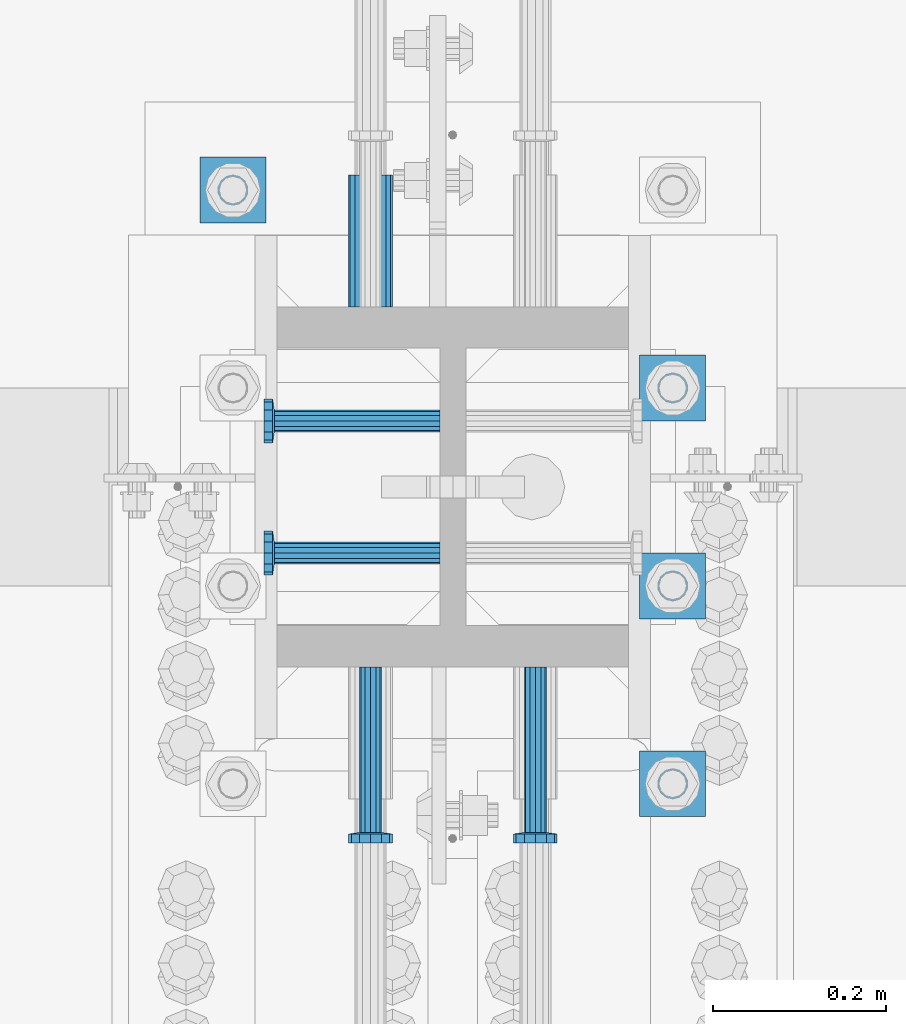
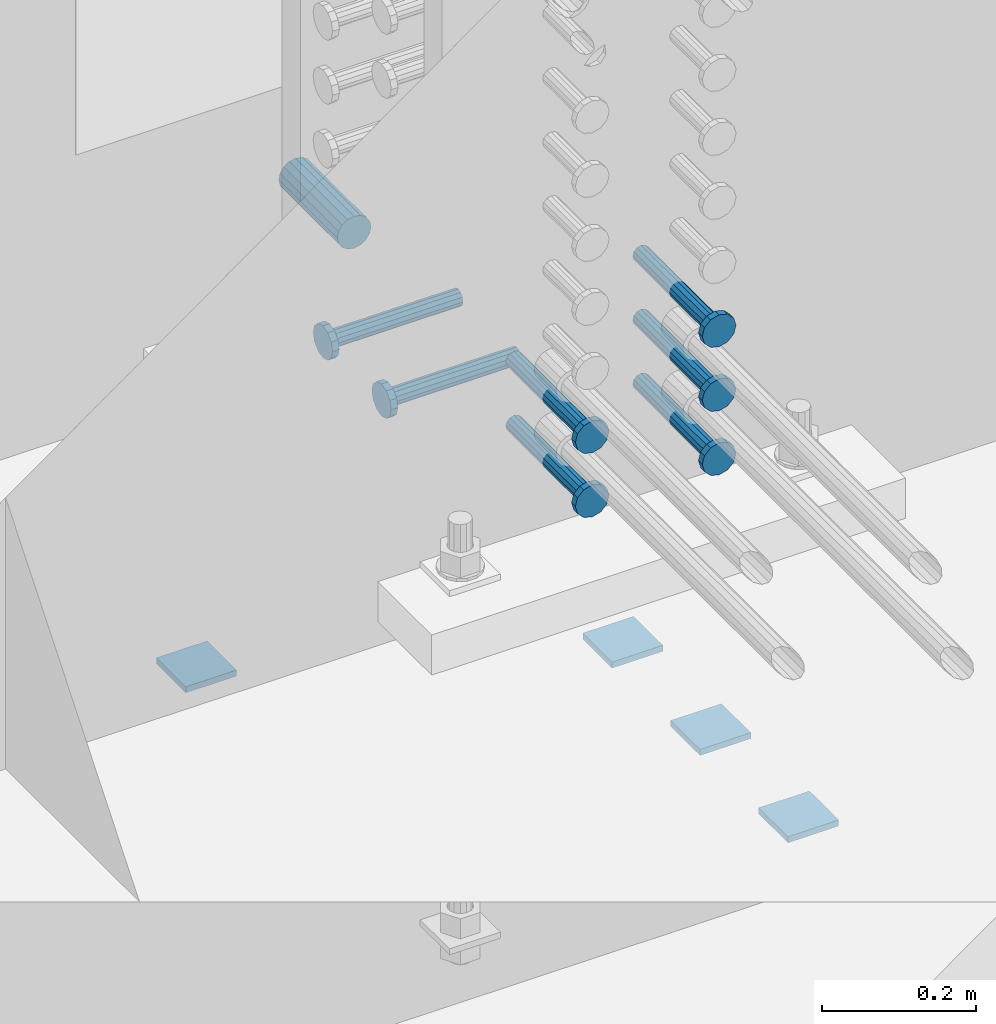
# One storey, part 1320 of 1763: 12 beams, 2 elements without a shape of their own.
"""IFC2X3 building model written with IfcOpenShell, lengths in millimetres."""

import ifcopenshell
import ifcopenshell.guid

model = None  # the IFC model being written
_history = None  # IfcOwnerHistory: only IFC2X3 demands one
_inside = {}  # id of a spatial element -> (the spatial element, [elements in it])
_under = {}  # id of a project, library or spatial element -> (it, [spatial elements below it])
_declared = {}  # id of a project -> (the project, [libraries it declares])
_typed = {}  # id of a type object -> (the type object, [elements of that type])
_made_of = {}  # id of a material, layer set ... -> (it, [elements and type objects made of it])


def new_model(schema):
    """Start an empty IFC model of exactly this schema.

    Asked for "IFC4X3", IfcOpenShell would pick the latest addendum, in which some entities
    have other attributes; the version numbers below select the first issue.
    IFC2X3 requires an IfcOwnerHistory on every rooted entity: one is made here for all.
    """
    global model, _history
    if schema == "IFC4X3":
        model = ifcopenshell.file(schema_version=(4, 3, 0, 0))
    else:
        model = ifcopenshell.file(schema=schema)
    _inside.clear()
    _under.clear()
    _declared.clear()
    _typed.clear()
    _made_of.clear()
    _history = None
    if model.schema == "IFC2X3":
        org = make("IfcOrganization", Name="unknown")
        user = make(
            "IfcPersonAndOrganization",
            ThePerson=make("IfcPerson", FamilyName="unknown"),
            TheOrganization=org,
        )
        app = make(
            "IfcApplication",
            ApplicationDeveloper=org,
            Version="unknown",
            ApplicationFullName="unknown",
            ApplicationIdentifier="unknown",
        )
        _history = make(
            "IfcOwnerHistory",
            OwningUser=user,
            OwningApplication=app,
            ChangeAction="ADDED",
            CreationDate=0,
        )
    return model


def make(cls, **values):
    """One entity of the class cls with the attributes given. An attribute that is None is left unset."""
    return model.create_entity(
        cls, **{name: value for name, value in values.items() if value is not None}
    )


def rooted(cls, **values):
    """An entity with a GlobalId (a new one), such as an element, a storey or a relation."""
    return make(cls, GlobalId=ifcopenshell.guid.new(), OwnerHistory=_history, **values)


def si_unit(unit_type, name, prefix=None):
    """IfcSIUnit, for example si_unit("LENGTHUNIT", "METRE", prefix="MILLI")."""
    return make("IfcSIUnit", UnitType=unit_type, Prefix=prefix, Name=name)


def assignment(units):
    """IfcUnitAssignment: the units of a project."""
    return None if units is None else make("IfcUnitAssignment", Units=units)


def point(xyz):
    """IfcCartesianPoint."""
    return None if xyz is None else make("IfcCartesianPoint", Coordinates=xyz)


def direction(xyz):
    """IfcDirection."""
    return None if xyz is None else make("IfcDirection", DirectionRatios=xyz)


def frame(location, z_axis=None, x_axis=None):
    """IfcAxis2Placement3D, a coordinate frame: its origin and axes. An axis left out is left unset."""
    return make(
        "IfcAxis2Placement3D",
        Location=point(location),
        Axis=direction(z_axis),
        RefDirection=direction(x_axis),
    )


def origin_with_axes():
    """The frame at (0, 0, 0) with the z axis (0, 0, 1) and the x axis (1, 0, 0) written out."""
    return frame((0.0, 0.0, 0.0), z_axis=(0.0, 0.0, 1.0), x_axis=(1.0, 0.0, 0.0))


def place(relative_to, where):
    """IfcLocalPlacement: puts the frame where relative to a parent placement (None: the world)."""
    return make(
        "IfcLocalPlacement", PlacementRelTo=relative_to, RelativePlacement=where
    )


def context(
    kind, dimensions, precision=None, world=None, true_north=None, identifier=None
):
    """IfcGeometricRepresentationContext, for example the 3D "Model" context."""
    return make(
        "IfcGeometricRepresentationContext",
        ContextIdentifier=identifier,
        ContextType=kind,
        CoordinateSpaceDimension=dimensions,
        Precision=precision,
        WorldCoordinateSystem=world,
        TrueNorth=true_north,
    )


def subcontext(parent, identifier, kind, view, scale=None):
    """IfcGeometricRepresentationSubContext, for example "Body" below "Model"."""
    return make(
        "IfcGeometricRepresentationSubContext",
        ContextIdentifier=identifier,
        ContextType=kind,
        ParentContext=parent,
        TargetScale=scale,
        TargetView=view,
    )


def project(units=None, contexts=None):
    """IfcProject with its units and contexts."""
    return rooted(
        "IfcProject",
        Name="project",
        RepresentationContexts=contexts,
        UnitsInContext=assignment(units),
    )


def spatial(cls, under=None, at=None, **own):
    """A site, building, storey or space (cls), placed at a placement, below another one or the project."""
    s = rooted(cls, ObjectPlacement=at, **own)
    if under is not None:
        _under.setdefault(under.id(), (under, []))[1].append(s)
    return s


def faces_of(points, faces, orient=None, outer=None):
    """IfcFace entities. A face is a list of loops; a loop is a list of indices into points, from 0.

    orient and outer hold one flag for each loop. By default every Orientation is true, the
    first loop of a face is its IfcFaceOuterBound and the others are IfcFaceBound.
    """
    made = []
    for i, loops in enumerate(faces):
        bounds = []
        for j, loop in enumerate(loops):
            is_outer = j == 0 if outer is None else outer[i][j]
            bounds.append(
                make(
                    "IfcFaceOuterBound" if is_outer else "IfcFaceBound",
                    Bound=make("IfcPolyLoop", Polygon=[points[k] for k in loop]),
                    Orientation=True if orient is None else orient[i][j],
                )
            )
        made.append(make("IfcFace", Bounds=bounds))
    return made


def faceted_brep(points, faces, orient=None, outer=None, voids=None):
    """IfcFacetedBrep: a solid bounded by flat faces; with voids (closed shells), ...WithVoids."""
    shared = [point(p) for p in points]
    hull = make("IfcClosedShell", CfsFaces=faces_of(shared, faces, orient, outer))
    if voids is None:
        return make("IfcFacetedBrep", Outer=hull)
    return make(
        "IfcFacetedBrepWithVoids",
        Outer=hull,
        Voids=[
            make(cls, CfsFaces=faces_of(shared, fs, o, b)) for cls, fs, o, b in voids
        ],
    )


def shape(context_of_items, identifier, shape_type, items):
    """IfcShapeRepresentation: the items that make up one representation, for example the "Body"."""
    return make(
        "IfcShapeRepresentation",
        ContextOfItems=context_of_items,
        RepresentationIdentifier=identifier,
        RepresentationType=shape_type,
        Items=items,
    )


def material(Name=None, Category=None):
    """IfcMaterial."""
    return make("IfcMaterial", Name=Name, Category=Category)


def made_of(thing, what):
    """Note that an element or type object is made of a material, layer set ...; save() writes the relation."""
    if what is not None:
        _made_of.setdefault(what.id(), (what, []))[1].append(thing)
    return thing


def type_object(cls, material=None, **own):
    """A type object (cls), such as IfcWallType, which elements share."""
    return made_of(rooted(cls, **own), material)


def element(
    cls,
    number,
    at=None,
    inside=None,
    cuts=None,
    type_object=None,
    material=None,
    context=None,
    identifier="Body",
    shape_type=None,
    held_by="IfcProductDefinitionShape",
    body=None,
    shapes=None,
    **own,
):
    """One element of the class cls, such as IfcWall. Its Tag is "e" and its number.

    at: its placement. inside: the storey or other place that contains it. cuts: it is an
    opening in that element (IfcRelVoidsElement). A single representation is given by context,
    identifier, shape_type and body (its items); several are given by shapes. held_by: the class
    of the entity that holds the representations. save() writes the other relations.
    """
    e = rooted(cls, Tag="e%d" % number, ObjectPlacement=at, **own)
    if body is not None:
        shapes = [shape(context, identifier, shape_type, body)]
    if shapes is not None:
        e.Representation = make(held_by, Representations=shapes)
    if inside is not None:
        _inside.setdefault(inside.id(), (inside, []))[1].append(e)
    if cuts is not None:
        rooted(
            "IfcRelVoidsElement", RelatingBuildingElement=cuts, RelatedOpeningElement=e
        )
    if type_object is not None:
        _typed.setdefault(type_object.id(), (type_object, []))[1].append(e)
    return made_of(e, material)


def aggregate(whole, parts):
    """IfcRelAggregates: a whole, such as a stair, and the parts it consists of."""
    return rooted("IfcRelAggregates", RelatingObject=whole, RelatedObjects=parts)


def save(model, path):
    """Write the relations noted so far, then the file.

    IfcRelAggregates (storeys below a building ...), IfcRelContainedInSpatialStructure (elements
    in a storey), IfcRelDefinesByType, IfcRelAssociatesMaterial and IfcRelDeclares: one each for
    every whole, place, type object, material and project.
    """
    for whole, parts in _under.values():
        aggregate(whole, parts)
    for where, things in _inside.values():
        rooted(
            "IfcRelContainedInSpatialStructure",
            RelatedElements=things,
            RelatingStructure=where,
        )
    for kind, things in _typed.values():
        rooted("IfcRelDefinesByType", RelatedObjects=things, RelatingType=kind)
    for what, things in _made_of.values():
        rooted("IfcRelAssociatesMaterial", RelatedObjects=things, RelatingMaterial=what)
    for by, libraries in _declared.values():
        rooted("IfcRelDeclares", RelatingContext=by, RelatedDefinitions=libraries)
    model.write(path)


model = new_model("IFC2X3")

# Units and contexts
model_context = context("Model", 3, precision=1e-05, world=origin_with_axes())
body_context = subcontext(model_context, "Body", "Model", "MODEL_VIEW")
ifc_project = project(units=[si_unit("LENGTHUNIT", "METRE", prefix="MILLI"), si_unit("AREAUNIT", "SQUARE_METRE"), si_unit("VOLUMEUNIT", "CUBIC_METRE"), si_unit("MASSUNIT", "GRAM", prefix="KILO"), si_unit("TIMEUNIT", "SECOND"), si_unit("PLANEANGLEUNIT", "RADIAN"), si_unit("SOLIDANGLEUNIT", "STERADIAN"), si_unit("THERMODYNAMICTEMPERATUREUNIT", "DEGREE_CELSIUS"), si_unit("LUMINOUSINTENSITYUNIT", "LUMEN")], contexts=[model_context])

# Site, building, storey
site_placement = place(None, origin_with_axes())
site = spatial("IfcSite", under=ifc_project, at=site_placement, CompositionType="ELEMENT")
building_placement = place(site_placement, origin_with_axes())
building = spatial("IfcBuilding", under=site, at=building_placement, Name="Undefined", CompositionType="ELEMENT")
storey_placement = place(building_placement, origin_with_axes())
storey = spatial("IfcBuildingStorey", under=building, at=storey_placement, Name="Undefined", CompositionType="ELEMENT", Elevation=0.0)

# Assembly, beams
assembly_1_placement = place(storey_placement, origin_with_axes())
assembly_1 = element("IfcElementAssembly", 1, at=assembly_1_placement, inside=storey, Name="TEMPLATE", AssemblyPlace="NOTDEFINED", PredefinedType="RIGID_FRAME")
ifc_material_1 = material(Name="STEEL/A36")
beam_type_1 = type_object("IfcBeamType", PredefinedType="NOTDEFINED")
beam_1_placement = place(assembly_1_placement, frame((-23773.8372736984, 13309.5999999999, 3348.0375), z_axis=(1.0, 0.0, 0.0), x_axis=(0.0, 1.0, 0.0)))
beam_1 = element("IfcBeam", 2, at=beam_1_placement, type_object=beam_type_1, material=ifc_material_1, Name="WASHER PLATE", context=body_context, shape_type="Brep", body=[
    faceted_brep([(0.0, 4.76249999999709, -38.1000000000004), (0.0, 4.76249999999709, 38.1000000000004), (76.2000000000007, 4.76249999999982, 38.0999999999985), (76.2000000000007, 4.76249999999982, -38.0999999999985), (0.0, -4.76249999999709, 38.1000000000004), (76.2000000000007, -4.76249999999982, 38.0999999999985), (0.0, -4.76249999999709, -38.1000000000004), (76.2000000000007, -4.76249999999982, -38.0999999999985)], [[[0, 1, 2, 3]], [[1, 4, 5, 2]], [[4, 6, 7, 5]], [[6, 0, 3, 7]], [[5, 7, 3, 2]], [[6, 4, 1, 0]]]),
])
beam_2_placement = place(assembly_1_placement, frame((-23773.8372736984, 13538.1999999999, 3348.0375), z_axis=(1.0, 0.0, 0.0), x_axis=(0.0, 1.0, 0.0)))
beam_2 = element("IfcBeam", 3, at=beam_2_placement, type_object=beam_type_1, material=ifc_material_1, Name="WASHER PLATE", context=body_context, shape_type="Brep", body=[
    faceted_brep([(0.0, 4.76249999999709, -38.1000000000004), (0.0, 4.76249999999709, 38.1000000000004), (76.2000000000007, 4.76249999999982, 38.0999999999985), (76.2000000000007, 4.76249999999982, -38.0999999999985), (0.0, -4.76249999999709, 38.1000000000004), (76.2000000000007, -4.76249999999982, 38.0999999999985), (0.0, -4.76249999999709, -38.1000000000004), (76.2000000000007, -4.76249999999982, -38.0999999999985)], [[[0, 1, 2, 3]], [[1, 4, 5, 2]], [[4, 6, 7, 5]], [[6, 0, 3, 7]], [[5, 7, 3, 2]], [[6, 4, 1, 0]]]),
])
beam_3_placement = place(assembly_1_placement, frame((-23773.8372736984, 13766.7999999999, 3348.0375), z_axis=(1.0, 0.0, 0.0), x_axis=(0.0, 1.0, 0.0)))
beam_3 = element("IfcBeam", 4, at=beam_3_placement, type_object=beam_type_1, material=ifc_material_1, Name="WASHER PLATE", context=body_context, shape_type="Brep", body=[
    faceted_brep([(0.0, 4.76249999999709, -38.1000000000004), (0.0, 4.76249999999709, 38.1000000000004), (76.2000000000007, 4.76249999999982, 38.0999999999985), (76.2000000000007, 4.76249999999982, -38.0999999999985), (0.0, -4.76249999999709, 38.1000000000004), (76.2000000000007, -4.76249999999982, 38.0999999999985), (0.0, -4.76249999999709, -38.1000000000004), (76.2000000000007, -4.76249999999982, -38.0999999999985)], [[[0, 1, 2, 3]], [[1, 4, 5, 2]], [[4, 6, 7, 5]], [[6, 0, 3, 7]], [[5, 7, 3, 2]], [[6, 4, 1, 0]]]),
])
beam_4_placement = place(assembly_1_placement, frame((-24281.8372736984, 13995.3999999999, 3348.0375), z_axis=(1.0, 0.0, 0.0), x_axis=(0.0, 1.0, 0.0)))
beam_4 = element("IfcBeam", 5, at=beam_4_placement, type_object=beam_type_1, material=ifc_material_1, Name="WASHER PLATE", context=body_context, shape_type="Brep", body=[
    faceted_brep([(0.0, 4.76249999999709, -38.1000000000004), (0.0, 4.76249999999709, 38.1000000000004), (76.2000000000007, 4.76249999999982, 38.0999999999985), (76.2000000000007, 4.76249999999982, -38.0999999999985), (0.0, -4.76249999999709, 38.1000000000004), (76.2000000000007, -4.76249999999982, 38.0999999999985), (0.0, -4.76249999999709, -38.1000000000004), (76.2000000000007, -4.76249999999982, -38.0999999999985)], [[[0, 1, 2, 3]], [[1, 4, 5, 2]], [[4, 6, 7, 5]], [[6, 0, 3, 7]], [[5, 7, 3, 2]], [[6, 4, 1, 0]]]),
])
aggregate(assembly_1, [beam_1, beam_2, beam_3, beam_4])

assembly_2_placement = place(storey_placement, origin_with_axes())
assembly_2 = element("IfcElementAssembly", 6, at=assembly_2_placement, inside=storey, Name="COLUMN", AssemblyPlace="NOTDEFINED", PredefinedType="RIGID_FRAME")
ifc_material_2 = material(Name="STEEL/A706-GR.80")
beam_type_2 = type_object("IfcBeamType", PredefinedType="NOTDEFINED")
beam_5_placement = place(assembly_2_placement, frame((-24123.0872736984, 13898.5623171099, 4064.0), z_axis=(0.0, 0.0, 1.0), x_axis=(0.0, 1.0, 0.0)))
beam_5 = element("IfcBeam", 7, at=beam_5_placement, type_object=beam_type_2, material=ifc_material_2, Name="HALF COUPLER F", context=body_context, shape_type="Brep", body=[
    faceted_brep([(32.7659999999996, -8.95349999999962, -15.507916905568), (32.7659999999996, 0.0, -17.9070000000002), (32.7659999999996, 8.95349999999962, -15.507916905568), (32.7659999999996, 15.507916905568, -8.95350000000008), (32.7659999999996, 17.9069999999992, 0.0), (32.7659999999996, 15.507916905568, 8.95350000000008), (32.7659999999996, 8.95349999999962, 15.507916905568), (32.7659999999996, 0.0, 17.9070000000002), (32.7659999999996, -8.95349999999962, 15.507916905568), (32.7659999999996, -15.507916905568, 8.95350000000008), (32.7659999999996, -17.9069999999992, 0.0), (32.7659999999996, -15.507916905568, -8.95350000000008), (152.400103102711, -15.507916905568, 8.95350000000008), (152.400103102711, -8.95349999999962, 15.507916905568), (152.400103102711, -17.9069999999992, 0.0), (152.400103102711, -15.507916905568, -8.95350000000008), (152.400103102711, -8.95349999999962, -15.507916905568), (152.400103102711, 0.0, -17.9070000000002), (152.400103102711, 8.95349999999962, -15.507916905568), (152.400103102711, 15.507916905568, -8.95350000000008), (152.400103102711, 17.9069999999992, 0.0), (152.400103102711, 15.507916905568, 8.95350000000008), (152.400103102711, 8.95349999999962, 15.507916905568), (152.400103102711, 0.0, 17.9070000000002), (0.0, -23.466540125788, 9.72015918207308), (0.0, -17.9605122421381, 17.9605122421385), (0.0, -9.72015918207398, 23.4665401257867), (0.0, 0.0, 25.4000000000001), (0.0, 9.72015918207398, 23.4665401257867), (0.0, 17.9605122421381, 17.9605122421385), (0.0, 23.466540125788, 9.72015918207308), (0.0, 25.4000000000015, 0.0), (0.0, 23.466540125788, -9.72015918207308), (0.0, 17.9605122421381, -17.9605122421385), (0.0, 9.72015918207398, -23.4665401257867), (0.0, 0.0, -25.4000000000001), (0.0, -9.72015918207398, -23.4665401257867), (0.0, -17.9605122421381, -17.9605122421385), (0.0, -23.466540125788, -9.72015918207308), (0.0, -25.4000000000015, 0.0), (152.400103102711, -25.4000000000015, 0.0), (152.400103102711, -23.466540125788, 9.72015918207308), (152.400103102711, -17.9605122421381, 17.9605122421385), (152.400103102711, -9.72015918207398, 23.4665401257867), (152.400103102711, 0.0, 25.4000000000001), (152.400103102711, 9.72015918207398, 23.4665401257867), (152.400103102711, 17.9605122421381, 17.9605122421385), (152.400103102711, 23.466540125788, 9.72015918207308), (152.400103102711, 25.4000000000015, 0.0), (152.400103102711, 23.466540125788, -9.72015918207308), (152.400103102711, 17.9605122421381, -17.9605122421385), (152.400103102711, 9.72015918207398, -23.4665401257867), (152.400103102711, 0.0, -25.4000000000001), (152.400103102711, -9.72015918207398, -23.4665401257867), (152.400103102711, -17.9605122421381, -17.9605122421385), (152.400103102711, -23.466540125788, -9.72015918207308)], [[[0, 1, 2, 3, 4, 5, 6, 7, 8, 9, 10, 11]], [[12, 9, 8, 13]], [[14, 10, 9, 12]], [[15, 11, 10, 14]], [[16, 0, 11, 15]], [[17, 1, 0, 16]], [[18, 2, 1, 17]], [[19, 3, 2, 18]], [[20, 4, 3, 19]], [[21, 5, 4, 20]], [[22, 6, 5, 21]], [[23, 7, 6, 22]], [[13, 8, 7, 23]], [[24, 25, 26, 27, 28, 29, 30, 31, 32, 33, 34, 35, 36, 37, 38, 39]], [[24, 39, 40, 41]], [[25, 24, 41, 42]], [[26, 25, 42, 43]], [[27, 26, 43, 44]], [[28, 27, 44, 45]], [[29, 28, 45, 46]], [[30, 29, 46, 47]], [[31, 30, 47, 48]], [[32, 31, 48, 49]], [[33, 32, 49, 50]], [[34, 33, 50, 51]], [[35, 34, 51, 52]], [[36, 35, 52, 53]], [[37, 36, 53, 54]], [[38, 37, 54, 55]], [[39, 38, 55, 40]], [[54, 53, 52, 51, 50, 49, 48, 47, 46, 45, 44, 43, 42, 41, 40, 55], [21, 20, 19, 18, 17, 16, 15, 14, 12, 13, 23, 22]]]),
])
ifc_material_3 = material(Name="STEEL/A108")
beam_type_3 = type_object("IfcBeamType", PredefinedType="NOTDEFINED")
beam_6_placement = place(assembly_2_placement, frame((-23932.5872736984, 13482.6374312644, 4216.40000000002), z_axis=(1.0, 0.0, 0.0), x_axis=(0.0, -1.0, 0.0)))
beam_6 = element("IfcBeam", 8, at=beam_6_placement, type_object=beam_type_3, material=ifc_material_3, Name="HEADED STUD ANCHOR", context=body_context, shape_type="Brep", body=[
    faceted_brep([(0.0, -12.6999999999971, -1.81898940354586e-12), (3.63797880709171e-12, -11.0, -6.34999990463257), (191.00799999576, -11.0, -6.34999990454889), (191.007999995752, -12.6999998092651, 8.36735125631094e-11), (7.27595761418343e-12, -6.34999990463257, -11.0), (191.00799999576, -6.34999990463257, -10.9999999999163), (3.63797880709171e-12, 0.0, -12.6999998092651), (191.00799999576, 0.0, -12.6999998091815), (7.27595761418343e-12, 6.34999990463257, -11.0), (191.00799999576, 6.34999990463257, -10.9999999999163), (3.63797880709171e-12, 11.0, -6.34999990463257), (191.00799999576, 11.0, -6.34999990454889), (0.0, 12.6999999999971, -1.81898940354586e-12), (191.007999995752, 12.6999998092651, 8.36735125631094e-11), (0.0, 11.0, 6.34999990463257), (191.007999995752, 11.0, 6.34999990471624), (-3.63797880709171e-12, 6.34999990463257, 11.0), (191.007999995749, 6.34999990463257, 11.0000000000837), (-3.63797880709171e-12, 0.0, 12.6999998092651), (191.007999995749, 0.0, 12.6999998093488), (-3.63797880709171e-12, -6.34999990463257, 11.0), (191.007999995749, -6.34999990463257, 11.0000000000837), (0.0, -11.0, 6.34999990463257), (191.007999995752, -11.0, 6.34999990471624), (193.039999995715, -22.0, -12.6999998091796), (193.039999995708, -25.3999996185303, 8.54925019666553e-11), (193.039999995719, -12.6999998092651, -21.9999999999145), (193.039999995719, 0.0, -25.3999996184448), (193.039999995719, 12.6999998092651, -21.9999999999145), (193.039999995715, 22.0, -12.6999998091796), (193.039999995708, 25.3999996185303, 8.54925019666553e-11), (193.039999995704, 22.0, 12.6999998093506), (193.039999995701, 12.6999998092651, 22.0000000000855), (193.039999995697, 0.0, 25.3999996186158), (193.039999995701, -12.6999998092651, 22.0000000000855), (193.039999995704, -22.0, 12.6999998093506), (203.199999995486, -22.0, -12.6999998091742), (203.199999995482, -25.3999996185303, 9.09494701772928e-11), (203.199999995493, -12.6999998092651, -21.9999999999091), (203.199999995493, 0.0, -25.3999996184393), (203.199999995493, 12.6999998092651, -21.9999999999091), (203.199999995486, 22.0, -12.6999998091742), (203.199999995482, 25.3999996185303, 9.09494701772928e-11), (203.199999995479, 22.0, 12.6999998093561), (203.199999995475, 12.6999998092651, 22.0000000000909), (203.199999995471, 0.0, 25.3999996186212), (203.199999995475, -12.6999998092651, 22.0000000000909), (203.199999995479, -22.0, 12.6999998093561)], [[[0, 1, 2, 3]], [[1, 4, 5, 2]], [[4, 6, 7, 5]], [[6, 8, 9, 7]], [[8, 10, 11, 9]], [[10, 12, 13, 11]], [[12, 14, 15, 13]], [[14, 16, 17, 15]], [[16, 18, 19, 17]], [[18, 20, 21, 19]], [[20, 22, 23, 21]], [[22, 0, 3, 23]], [[22, 20, 18, 16, 14, 12, 10, 8, 6, 4, 1, 0]], [[3, 2, 24, 25]], [[2, 5, 26, 24]], [[5, 7, 27, 26]], [[7, 9, 28, 27]], [[9, 11, 29, 28]], [[11, 13, 30, 29]], [[13, 15, 31, 30]], [[15, 17, 32, 31]], [[17, 19, 33, 32]], [[19, 21, 34, 33]], [[21, 23, 35, 34]], [[23, 3, 25, 35]], [[25, 24, 36, 37]], [[24, 26, 38, 36]], [[26, 27, 39, 38]], [[27, 28, 40, 39]], [[28, 29, 41, 40]], [[29, 30, 42, 41]], [[30, 31, 43, 42]], [[31, 32, 44, 43]], [[32, 33, 45, 44]], [[33, 34, 46, 45]], [[34, 35, 47, 46]], [[35, 25, 37, 47]], [[38, 39, 40, 41, 42, 43, 44, 45, 46, 47, 37, 36]]]),
])
beam_7_placement = place(assembly_2_placement, frame((-24123.0872736978, 13482.6374999249, 4114.80000000002), z_axis=(1.0, 0.0, 0.0), x_axis=(0.0, -1.0, 0.0)))
beam_7 = element("IfcBeam", 9, at=beam_7_placement, type_object=beam_type_3, material=ifc_material_3, Name="HEADED STUD ANCHOR", context=body_context, shape_type="Brep", body=[
    faceted_brep([(0.0, -12.6999999999971, -1.81898940354586e-12), (3.63797880709171e-12, -11.0, -6.34999990463257), (191.00799999576, -11.0, -6.34999990454889), (191.007999995752, -12.6999998092651, 8.36735125631094e-11), (7.27595761418343e-12, -6.34999990463257, -11.0), (191.00799999576, -6.34999990463257, -10.9999999999163), (3.63797880709171e-12, 0.0, -12.6999998092651), (191.00799999576, 0.0, -12.6999998091815), (7.27595761418343e-12, 6.34999990463257, -11.0), (191.00799999576, 6.34999990463257, -10.9999999999163), (3.63797880709171e-12, 11.0, -6.34999990463257), (191.00799999576, 11.0, -6.34999990454889), (0.0, 12.6999999999971, -1.81898940354586e-12), (191.007999995752, 12.6999998092651, 8.36735125631094e-11), (0.0, 11.0, 6.34999990463257), (191.007999995752, 11.0, 6.34999990471624), (-3.63797880709171e-12, 6.34999990463257, 11.0), (191.007999995749, 6.34999990463257, 11.0000000000837), (-3.63797880709171e-12, 0.0, 12.6999998092651), (191.007999995749, 0.0, 12.6999998093488), (-3.63797880709171e-12, -6.34999990463257, 11.0), (191.007999995749, -6.34999990463257, 11.0000000000837), (0.0, -11.0, 6.34999990463257), (191.007999995752, -11.0, 6.34999990471624), (193.039999995715, -22.0, -12.6999998091796), (193.039999995708, -25.3999996185303, 8.54925019666553e-11), (193.039999995719, -12.6999998092651, -21.9999999999145), (193.039999995719, 0.0, -25.3999996184448), (193.039999995719, 12.6999998092651, -21.9999999999145), (193.039999995715, 22.0, -12.6999998091796), (193.039999995708, 25.3999996185303, 8.54925019666553e-11), (193.039999995704, 22.0, 12.6999998093506), (193.039999995701, 12.6999998092651, 22.0000000000855), (193.039999995697, 0.0, 25.3999996186158), (193.039999995701, -12.6999998092651, 22.0000000000855), (193.039999995704, -22.0, 12.6999998093506), (203.199999995486, -22.0, -12.6999998091742), (203.199999995482, -25.3999996185303, 9.09494701772928e-11), (203.199999995493, -12.6999998092651, -21.9999999999091), (203.199999995493, 0.0, -25.3999996184393), (203.199999995493, 12.6999998092651, -21.9999999999091), (203.199999995486, 22.0, -12.6999998091742), (203.199999995482, 25.3999996185303, 9.09494701772928e-11), (203.199999995479, 22.0, 12.6999998093561), (203.199999995475, 12.6999998092651, 22.0000000000909), (203.199999995471, 0.0, 25.3999996186212), (203.199999995475, -12.6999998092651, 22.0000000000909), (203.199999995479, -22.0, 12.6999998093561)], [[[0, 1, 2, 3]], [[1, 4, 5, 2]], [[4, 6, 7, 5]], [[6, 8, 9, 7]], [[8, 10, 11, 9]], [[10, 12, 13, 11]], [[12, 14, 15, 13]], [[14, 16, 17, 15]], [[16, 18, 19, 17]], [[18, 20, 21, 19]], [[20, 22, 23, 21]], [[22, 0, 3, 23]], [[22, 20, 18, 16, 14, 12, 10, 8, 6, 4, 1, 0]], [[3, 2, 24, 25]], [[2, 5, 26, 24]], [[5, 7, 27, 26]], [[7, 9, 28, 27]], [[9, 11, 29, 28]], [[11, 13, 30, 29]], [[13, 15, 31, 30]], [[15, 17, 32, 31]], [[17, 19, 33, 32]], [[19, 21, 34, 33]], [[21, 23, 35, 34]], [[23, 3, 25, 35]], [[25, 24, 36, 37]], [[24, 26, 38, 36]], [[26, 27, 39, 38]], [[27, 28, 40, 39]], [[28, 29, 41, 40]], [[29, 30, 42, 41]], [[30, 31, 43, 42]], [[31, 32, 44, 43]], [[32, 33, 45, 44]], [[33, 34, 46, 45]], [[34, 35, 47, 46]], [[35, 25, 37, 47]], [[38, 39, 40, 41, 42, 43, 44, 45, 46, 47, 37, 36]]]),
])
beam_8_placement = place(assembly_2_placement, frame((-23932.5872736984, 13482.6374312644, 4114.80000000002), z_axis=(1.0, 0.0, 0.0), x_axis=(0.0, -1.0, 0.0)))
beam_8 = element("IfcBeam", 10, at=beam_8_placement, type_object=beam_type_3, material=ifc_material_3, Name="HEADED STUD ANCHOR", context=body_context, shape_type="Brep", body=[
    faceted_brep([(0.0, -12.6999999999971, -1.81898940354586e-12), (3.63797880709171e-12, -11.0, -6.34999990463257), (191.00799999576, -11.0, -6.34999990454889), (191.007999995752, -12.6999998092651, 8.36735125631094e-11), (7.27595761418343e-12, -6.34999990463257, -11.0), (191.00799999576, -6.34999990463257, -10.9999999999163), (3.63797880709171e-12, 0.0, -12.6999998092651), (191.00799999576, 0.0, -12.6999998091815), (7.27595761418343e-12, 6.34999990463257, -11.0), (191.00799999576, 6.34999990463257, -10.9999999999163), (3.63797880709171e-12, 11.0, -6.34999990463257), (191.00799999576, 11.0, -6.34999990454889), (0.0, 12.6999999999971, -1.81898940354586e-12), (191.007999995752, 12.6999998092651, 8.36735125631094e-11), (0.0, 11.0, 6.34999990463257), (191.007999995752, 11.0, 6.34999990471624), (-3.63797880709171e-12, 6.34999990463257, 11.0), (191.007999995749, 6.34999990463257, 11.0000000000837), (-3.63797880709171e-12, 0.0, 12.6999998092651), (191.007999995749, 0.0, 12.6999998093488), (-3.63797880709171e-12, -6.34999990463257, 11.0), (191.007999995749, -6.34999990463257, 11.0000000000837), (0.0, -11.0, 6.34999990463257), (191.007999995752, -11.0, 6.34999990471624), (193.039999995715, -22.0, -12.6999998091796), (193.039999995708, -25.3999996185303, 8.54925019666553e-11), (193.039999995719, -12.6999998092651, -21.9999999999145), (193.039999995719, 0.0, -25.3999996184448), (193.039999995719, 12.6999998092651, -21.9999999999145), (193.039999995715, 22.0, -12.6999998091796), (193.039999995708, 25.3999996185303, 8.54925019666553e-11), (193.039999995704, 22.0, 12.6999998093506), (193.039999995701, 12.6999998092651, 22.0000000000855), (193.039999995697, 0.0, 25.3999996186158), (193.039999995701, -12.6999998092651, 22.0000000000855), (193.039999995704, -22.0, 12.6999998093506), (203.199999995486, -22.0, -12.6999998091742), (203.199999995482, -25.3999996185303, 9.09494701772928e-11), (203.199999995493, -12.6999998092651, -21.9999999999091), (203.199999995493, 0.0, -25.3999996184393), (203.199999995493, 12.6999998092651, -21.9999999999091), (203.199999995486, 22.0, -12.6999998091742), (203.199999995482, 25.3999996185303, 9.09494701772928e-11), (203.199999995479, 22.0, 12.6999998093561), (203.199999995475, 12.6999998092651, 22.0000000000909), (203.199999995471, 0.0, 25.3999996186212), (203.199999995475, -12.6999998092651, 22.0000000000909), (203.199999995479, -22.0, 12.6999998093561)], [[[0, 1, 2, 3]], [[1, 4, 5, 2]], [[4, 6, 7, 5]], [[6, 8, 9, 7]], [[8, 10, 11, 9]], [[10, 12, 13, 11]], [[12, 14, 15, 13]], [[14, 16, 17, 15]], [[16, 18, 19, 17]], [[18, 20, 21, 19]], [[20, 22, 23, 21]], [[22, 0, 3, 23]], [[22, 20, 18, 16, 14, 12, 10, 8, 6, 4, 1, 0]], [[3, 2, 24, 25]], [[2, 5, 26, 24]], [[5, 7, 27, 26]], [[7, 9, 28, 27]], [[9, 11, 29, 28]], [[11, 13, 30, 29]], [[13, 15, 31, 30]], [[15, 17, 32, 31]], [[17, 19, 33, 32]], [[19, 21, 34, 33]], [[21, 23, 35, 34]], [[23, 3, 25, 35]], [[25, 24, 36, 37]], [[24, 26, 38, 36]], [[26, 27, 39, 38]], [[27, 28, 40, 39]], [[28, 29, 41, 40]], [[29, 30, 42, 41]], [[30, 31, 43, 42]], [[31, 32, 44, 43]], [[32, 33, 45, 44]], [[33, 34, 46, 45]], [[34, 35, 47, 46]], [[35, 25, 37, 47]], [[38, 39, 40, 41, 42, 43, 44, 45, 46, 47, 37, 36]]]),
])
beam_9_placement = place(assembly_2_placement, frame((-24042.9185299162, 13766.799999658, 4013.2), z_axis=(0.0, -1.0, 0.0), x_axis=(-1.0, 0.0, 0.0)))
beam_9 = element("IfcBeam", 11, at=beam_9_placement, type_object=beam_type_3, material=ifc_material_3, Name="HEADED STUD ANCHOR", context=body_context, shape_type="Brep", body=[
    faceted_brep([(0.0, -12.6999999999971, -1.81898940354586e-12), (3.63797880709171e-12, -11.0, -6.34999990463257), (191.00799999576, -11.0, -6.34999990454889), (191.007999995752, -12.6999998092651, 8.36735125631094e-11), (7.27595761418343e-12, -6.34999990463257, -11.0), (191.00799999576, -6.34999990463257, -10.9999999999163), (3.63797880709171e-12, 0.0, -12.6999998092651), (191.00799999576, 0.0, -12.6999998091815), (7.27595761418343e-12, 6.34999990463257, -11.0), (191.00799999576, 6.34999990463257, -10.9999999999163), (3.63797880709171e-12, 11.0, -6.34999990463257), (191.00799999576, 11.0, -6.34999990454889), (0.0, 12.6999999999971, -1.81898940354586e-12), (191.007999995752, 12.6999998092651, 8.36735125631094e-11), (0.0, 11.0, 6.34999990463257), (191.007999995752, 11.0, 6.34999990471624), (-3.63797880709171e-12, 6.34999990463257, 11.0), (191.007999995749, 6.34999990463257, 11.0000000000837), (-3.63797880709171e-12, 0.0, 12.6999998092651), (191.007999995749, 0.0, 12.6999998093488), (-3.63797880709171e-12, -6.34999990463257, 11.0), (191.007999995749, -6.34999990463257, 11.0000000000837), (0.0, -11.0, 6.34999990463257), (191.007999995752, -11.0, 6.34999990471624), (193.039999995715, -22.0, -12.6999998091796), (193.039999995708, -25.3999996185303, 8.54925019666553e-11), (193.039999995719, -12.6999998092651, -21.9999999999145), (193.039999995719, 0.0, -25.3999996184448), (193.039999995719, 12.6999998092651, -21.9999999999145), (193.039999995715, 22.0, -12.6999998091796), (193.039999995708, 25.3999996185303, 8.54925019666553e-11), (193.039999995704, 22.0, 12.6999998093506), (193.039999995701, 12.6999998092651, 22.0000000000855), (193.039999995697, 0.0, 25.3999996186158), (193.039999995701, -12.6999998092651, 22.0000000000855), (193.039999995704, -22.0, 12.6999998093506), (203.199999995486, -22.0, -12.6999998091742), (203.199999995482, -25.3999996185303, 9.09494701772928e-11), (203.199999995493, -12.6999998092651, -21.9999999999091), (203.199999995493, 0.0, -25.3999996184393), (203.199999995493, 12.6999998092651, -21.9999999999091), (203.199999995486, 22.0, -12.6999998091742), (203.199999995482, 25.3999996185303, 9.09494701772928e-11), (203.199999995479, 22.0, 12.6999998093561), (203.199999995475, 12.6999998092651, 22.0000000000909), (203.199999995471, 0.0, 25.3999996186212), (203.199999995475, -12.6999998092651, 22.0000000000909), (203.199999995479, -22.0, 12.6999998093561)], [[[0, 1, 2, 3]], [[1, 4, 5, 2]], [[4, 6, 7, 5]], [[6, 8, 9, 7]], [[8, 10, 11, 9]], [[10, 12, 13, 11]], [[12, 14, 15, 13]], [[14, 16, 17, 15]], [[16, 18, 19, 17]], [[18, 20, 21, 19]], [[20, 22, 23, 21]], [[22, 0, 3, 23]], [[22, 20, 18, 16, 14, 12, 10, 8, 6, 4, 1, 0]], [[3, 2, 24, 25]], [[2, 5, 26, 24]], [[5, 7, 27, 26]], [[7, 9, 28, 27]], [[9, 11, 29, 28]], [[11, 13, 30, 29]], [[13, 15, 31, 30]], [[15, 17, 32, 31]], [[17, 19, 33, 32]], [[19, 21, 34, 33]], [[21, 23, 35, 34]], [[23, 3, 25, 35]], [[25, 24, 36, 37]], [[24, 26, 38, 36]], [[26, 27, 39, 38]], [[27, 28, 40, 39]], [[28, 29, 41, 40]], [[29, 30, 42, 41]], [[30, 31, 43, 42]], [[31, 32, 44, 43]], [[32, 33, 45, 44]], [[33, 34, 46, 45]], [[34, 35, 47, 46]], [[35, 25, 37, 47]], [[38, 39, 40, 41, 42, 43, 44, 45, 46, 47, 37, 36]]]),
])
beam_10_placement = place(assembly_2_placement, frame((-24042.9185298019, 13614.3999996589, 4013.2), z_axis=(0.0, -1.0, 0.0), x_axis=(-1.0, 0.0, 0.0)))
beam_10 = element("IfcBeam", 12, at=beam_10_placement, type_object=beam_type_3, material=ifc_material_3, Name="HEADED STUD ANCHOR", context=body_context, shape_type="Brep", body=[
    faceted_brep([(0.0, -12.6999999999971, -1.81898940354586e-12), (3.63797880709171e-12, -11.0, -6.34999990463257), (191.00799999576, -11.0, -6.34999990454889), (191.007999995752, -12.6999998092651, 8.36735125631094e-11), (7.27595761418343e-12, -6.34999990463257, -11.0), (191.00799999576, -6.34999990463257, -10.9999999999163), (3.63797880709171e-12, 0.0, -12.6999998092651), (191.00799999576, 0.0, -12.6999998091815), (7.27595761418343e-12, 6.34999990463257, -11.0), (191.00799999576, 6.34999990463257, -10.9999999999163), (3.63797880709171e-12, 11.0, -6.34999990463257), (191.00799999576, 11.0, -6.34999990454889), (0.0, 12.6999999999971, -1.81898940354586e-12), (191.007999995752, 12.6999998092651, 8.36735125631094e-11), (0.0, 11.0, 6.34999990463257), (191.007999995752, 11.0, 6.34999990471624), (-3.63797880709171e-12, 6.34999990463257, 11.0), (191.007999995749, 6.34999990463257, 11.0000000000837), (-3.63797880709171e-12, 0.0, 12.6999998092651), (191.007999995749, 0.0, 12.6999998093488), (-3.63797880709171e-12, -6.34999990463257, 11.0), (191.007999995749, -6.34999990463257, 11.0000000000837), (0.0, -11.0, 6.34999990463257), (191.007999995752, -11.0, 6.34999990471624), (193.039999995715, -22.0, -12.6999998091796), (193.039999995708, -25.3999996185303, 8.54925019666553e-11), (193.039999995719, -12.6999998092651, -21.9999999999145), (193.039999995719, 0.0, -25.3999996184448), (193.039999995719, 12.6999998092651, -21.9999999999145), (193.039999995715, 22.0, -12.6999998091796), (193.039999995708, 25.3999996185303, 8.54925019666553e-11), (193.039999995704, 22.0, 12.6999998093506), (193.039999995701, 12.6999998092651, 22.0000000000855), (193.039999995697, 0.0, 25.3999996186158), (193.039999995701, -12.6999998092651, 22.0000000000855), (193.039999995704, -22.0, 12.6999998093506), (203.199999995486, -22.0, -12.6999998091742), (203.199999995482, -25.3999996185303, 9.09494701772928e-11), (203.199999995493, -12.6999998092651, -21.9999999999091), (203.199999995493, 0.0, -25.3999996184393), (203.199999995493, 12.6999998092651, -21.9999999999091), (203.199999995486, 22.0, -12.6999998091742), (203.199999995482, 25.3999996185303, 9.09494701772928e-11), (203.199999995479, 22.0, 12.6999998093561), (203.199999995475, 12.6999998092651, 22.0000000000909), (203.199999995471, 0.0, 25.3999996186212), (203.199999995475, -12.6999998092651, 22.0000000000909), (203.199999995479, -22.0, 12.6999998093561)], [[[0, 1, 2, 3]], [[1, 4, 5, 2]], [[4, 6, 7, 5]], [[6, 8, 9, 7]], [[8, 10, 11, 9]], [[10, 12, 13, 11]], [[12, 14, 15, 13]], [[14, 16, 17, 15]], [[16, 18, 19, 17]], [[18, 20, 21, 19]], [[20, 22, 23, 21]], [[22, 0, 3, 23]], [[22, 20, 18, 16, 14, 12, 10, 8, 6, 4, 1, 0]], [[3, 2, 24, 25]], [[2, 5, 26, 24]], [[5, 7, 27, 26]], [[7, 9, 28, 27]], [[9, 11, 29, 28]], [[11, 13, 30, 29]], [[13, 15, 31, 30]], [[15, 17, 32, 31]], [[17, 19, 33, 32]], [[19, 21, 34, 33]], [[21, 23, 35, 34]], [[23, 3, 25, 35]], [[25, 24, 36, 37]], [[24, 26, 38, 36]], [[26, 27, 39, 38]], [[27, 28, 40, 39]], [[28, 29, 41, 40]], [[29, 30, 42, 41]], [[30, 31, 43, 42]], [[31, 32, 44, 43]], [[32, 33, 45, 44]], [[33, 34, 46, 45]], [[34, 35, 47, 46]], [[35, 25, 37, 47]], [[38, 39, 40, 41, 42, 43, 44, 45, 46, 47, 37, 36]]]),
])
beam_11_placement = place(assembly_2_placement, frame((-24123.0872736978, 13482.63743119, 4013.2), z_axis=(1.0, 0.0, 0.0), x_axis=(0.0, -1.0, 0.0)))
beam_11 = element("IfcBeam", 13, at=beam_11_placement, type_object=beam_type_3, material=ifc_material_3, Name="HEADED STUD ANCHOR", context=body_context, shape_type="Brep", body=[
    faceted_brep([(0.0, -12.6999999999971, -1.81898940354586e-12), (3.63797880709171e-12, -11.0, -6.34999990463257), (191.00799999576, -11.0, -6.34999990454889), (191.007999995752, -12.6999998092651, 8.36735125631094e-11), (7.27595761418343e-12, -6.34999990463257, -11.0), (191.00799999576, -6.34999990463257, -10.9999999999163), (3.63797880709171e-12, 0.0, -12.6999998092651), (191.00799999576, 0.0, -12.6999998091815), (7.27595761418343e-12, 6.34999990463257, -11.0), (191.00799999576, 6.34999990463257, -10.9999999999163), (3.63797880709171e-12, 11.0, -6.34999990463257), (191.00799999576, 11.0, -6.34999990454889), (0.0, 12.6999999999971, -1.81898940354586e-12), (191.007999995752, 12.6999998092651, 8.36735125631094e-11), (0.0, 11.0, 6.34999990463257), (191.007999995752, 11.0, 6.34999990471624), (-3.63797880709171e-12, 6.34999990463257, 11.0), (191.007999995749, 6.34999990463257, 11.0000000000837), (-3.63797880709171e-12, 0.0, 12.6999998092651), (191.007999995749, 0.0, 12.6999998093488), (-3.63797880709171e-12, -6.34999990463257, 11.0), (191.007999995749, -6.34999990463257, 11.0000000000837), (0.0, -11.0, 6.34999990463257), (191.007999995752, -11.0, 6.34999990471624), (193.039999995715, -22.0, -12.6999998091796), (193.039999995708, -25.3999996185303, 8.54925019666553e-11), (193.039999995719, -12.6999998092651, -21.9999999999145), (193.039999995719, 0.0, -25.3999996184448), (193.039999995719, 12.6999998092651, -21.9999999999145), (193.039999995715, 22.0, -12.6999998091796), (193.039999995708, 25.3999996185303, 8.54925019666553e-11), (193.039999995704, 22.0, 12.6999998093506), (193.039999995701, 12.6999998092651, 22.0000000000855), (193.039999995697, 0.0, 25.3999996186158), (193.039999995701, -12.6999998092651, 22.0000000000855), (193.039999995704, -22.0, 12.6999998093506), (203.199999995486, -22.0, -12.6999998091742), (203.199999995482, -25.3999996185303, 9.09494701772928e-11), (203.199999995493, -12.6999998092651, -21.9999999999091), (203.199999995493, 0.0, -25.3999996184393), (203.199999995493, 12.6999998092651, -21.9999999999091), (203.199999995486, 22.0, -12.6999998091742), (203.199999995482, 25.3999996185303, 9.09494701772928e-11), (203.199999995479, 22.0, 12.6999998093561), (203.199999995475, 12.6999998092651, 22.0000000000909), (203.199999995471, 0.0, 25.3999996186212), (203.199999995475, -12.6999998092651, 22.0000000000909), (203.199999995479, -22.0, 12.6999998093561)], [[[0, 1, 2, 3]], [[1, 4, 5, 2]], [[4, 6, 7, 5]], [[6, 8, 9, 7]], [[8, 10, 11, 9]], [[10, 12, 13, 11]], [[12, 14, 15, 13]], [[14, 16, 17, 15]], [[16, 18, 19, 17]], [[18, 20, 21, 19]], [[20, 22, 23, 21]], [[22, 0, 3, 23]], [[22, 20, 18, 16, 14, 12, 10, 8, 6, 4, 1, 0]], [[3, 2, 24, 25]], [[2, 5, 26, 24]], [[5, 7, 27, 26]], [[7, 9, 28, 27]], [[9, 11, 29, 28]], [[11, 13, 30, 29]], [[13, 15, 31, 30]], [[15, 17, 32, 31]], [[17, 19, 33, 32]], [[19, 21, 34, 33]], [[21, 23, 35, 34]], [[23, 3, 25, 35]], [[25, 24, 36, 37]], [[24, 26, 38, 36]], [[26, 27, 39, 38]], [[27, 28, 40, 39]], [[28, 29, 41, 40]], [[29, 30, 42, 41]], [[30, 31, 43, 42]], [[31, 32, 44, 43]], [[32, 33, 45, 44]], [[33, 34, 46, 45]], [[34, 35, 47, 46]], [[35, 25, 37, 47]], [[38, 39, 40, 41, 42, 43, 44, 45, 46, 47, 37, 36]]]),
])
beam_12_placement = place(assembly_2_placement, frame((-23932.5872736984, 13482.6373625295, 4013.2), z_axis=(1.0, 0.0, 0.0), x_axis=(0.0, -1.0, 0.0)))
beam_12 = element("IfcBeam", 14, at=beam_12_placement, type_object=beam_type_3, material=ifc_material_3, Name="HEADED STUD ANCHOR", context=body_context, shape_type="Brep", body=[
    faceted_brep([(0.0, -12.6999999999971, -1.81898940354586e-12), (3.63797880709171e-12, -11.0, -6.34999990463257), (191.00799999576, -11.0, -6.34999990454889), (191.007999995752, -12.6999998092651, 8.36735125631094e-11), (7.27595761418343e-12, -6.34999990463257, -11.0), (191.00799999576, -6.34999990463257, -10.9999999999163), (3.63797880709171e-12, 0.0, -12.6999998092651), (191.00799999576, 0.0, -12.6999998091815), (7.27595761418343e-12, 6.34999990463257, -11.0), (191.00799999576, 6.34999990463257, -10.9999999999163), (3.63797880709171e-12, 11.0, -6.34999990463257), (191.00799999576, 11.0, -6.34999990454889), (0.0, 12.6999999999971, -1.81898940354586e-12), (191.007999995752, 12.6999998092651, 8.36735125631094e-11), (0.0, 11.0, 6.34999990463257), (191.007999995752, 11.0, 6.34999990471624), (-3.63797880709171e-12, 6.34999990463257, 11.0), (191.007999995749, 6.34999990463257, 11.0000000000837), (-3.63797880709171e-12, 0.0, 12.6999998092651), (191.007999995749, 0.0, 12.6999998093488), (-3.63797880709171e-12, -6.34999990463257, 11.0), (191.007999995749, -6.34999990463257, 11.0000000000837), (0.0, -11.0, 6.34999990463257), (191.007999995752, -11.0, 6.34999990471624), (193.039999995715, -22.0, -12.6999998091796), (193.039999995708, -25.3999996185303, 8.54925019666553e-11), (193.039999995719, -12.6999998092651, -21.9999999999145), (193.039999995719, 0.0, -25.3999996184448), (193.039999995719, 12.6999998092651, -21.9999999999145), (193.039999995715, 22.0, -12.6999998091796), (193.039999995708, 25.3999996185303, 8.54925019666553e-11), (193.039999995704, 22.0, 12.6999998093506), (193.039999995701, 12.6999998092651, 22.0000000000855), (193.039999995697, 0.0, 25.3999996186158), (193.039999995701, -12.6999998092651, 22.0000000000855), (193.039999995704, -22.0, 12.6999998093506), (203.199999995486, -22.0, -12.6999998091742), (203.199999995482, -25.3999996185303, 9.09494701772928e-11), (203.199999995493, -12.6999998092651, -21.9999999999091), (203.199999995493, 0.0, -25.3999996184393), (203.199999995493, 12.6999998092651, -21.9999999999091), (203.199999995486, 22.0, -12.6999998091742), (203.199999995482, 25.3999996185303, 9.09494701772928e-11), (203.199999995479, 22.0, 12.6999998093561), (203.199999995475, 12.6999998092651, 22.0000000000909), (203.199999995471, 0.0, 25.3999996186212), (203.199999995475, -12.6999998092651, 22.0000000000909), (203.199999995479, -22.0, 12.6999998093561)], [[[0, 1, 2, 3]], [[1, 4, 5, 2]], [[4, 6, 7, 5]], [[6, 8, 9, 7]], [[8, 10, 11, 9]], [[10, 12, 13, 11]], [[12, 14, 15, 13]], [[14, 16, 17, 15]], [[16, 18, 19, 17]], [[18, 20, 21, 19]], [[20, 22, 23, 21]], [[22, 0, 3, 23]], [[22, 20, 18, 16, 14, 12, 10, 8, 6, 4, 1, 0]], [[3, 2, 24, 25]], [[2, 5, 26, 24]], [[5, 7, 27, 26]], [[7, 9, 28, 27]], [[9, 11, 29, 28]], [[11, 13, 30, 29]], [[13, 15, 31, 30]], [[15, 17, 32, 31]], [[17, 19, 33, 32]], [[19, 21, 34, 33]], [[21, 23, 35, 34]], [[23, 3, 25, 35]], [[25, 24, 36, 37]], [[24, 26, 38, 36]], [[26, 27, 39, 38]], [[27, 28, 40, 39]], [[28, 29, 41, 40]], [[29, 30, 42, 41]], [[30, 31, 43, 42]], [[31, 32, 44, 43]], [[32, 33, 45, 44]], [[33, 34, 46, 45]], [[34, 35, 47, 46]], [[35, 25, 37, 47]], [[38, 39, 40, 41, 42, 43, 44, 45, 46, 47, 37, 36]]]),
])
aggregate(assembly_2, [beam_5, beam_6, beam_7, beam_8, beam_9, beam_10, beam_11, beam_12])

save(model, "model.ifc")
